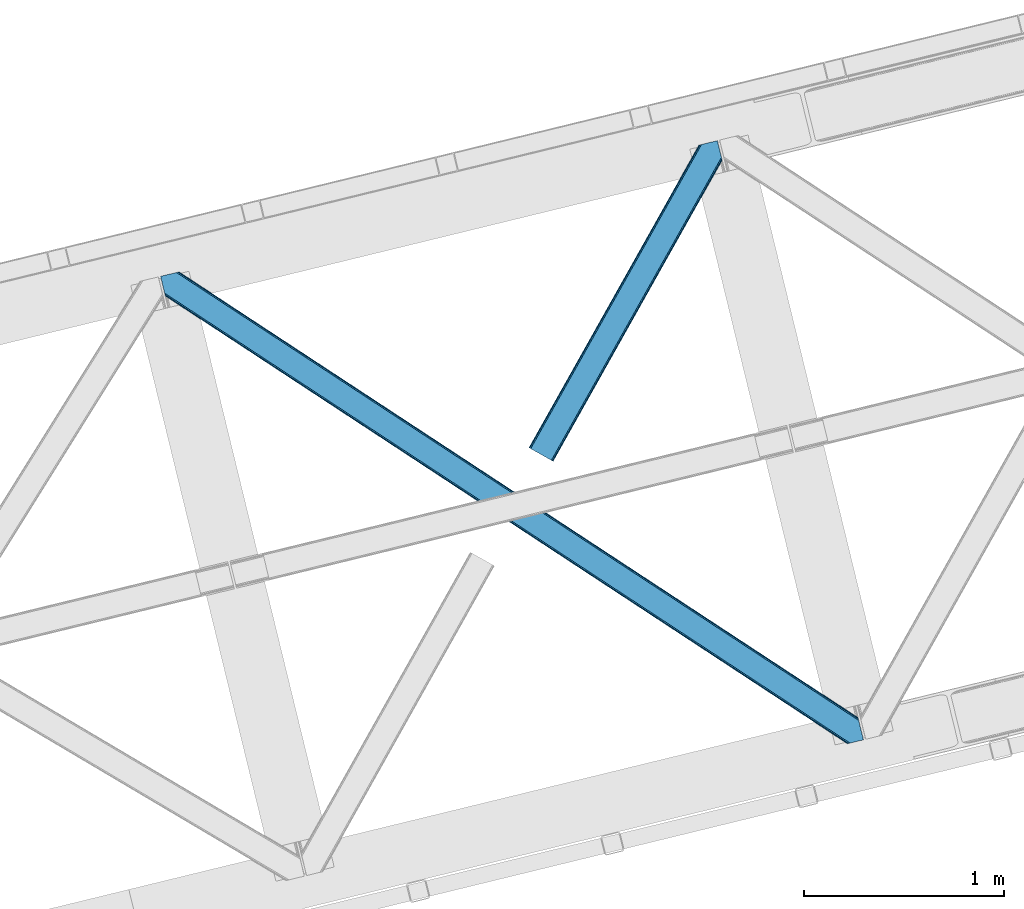
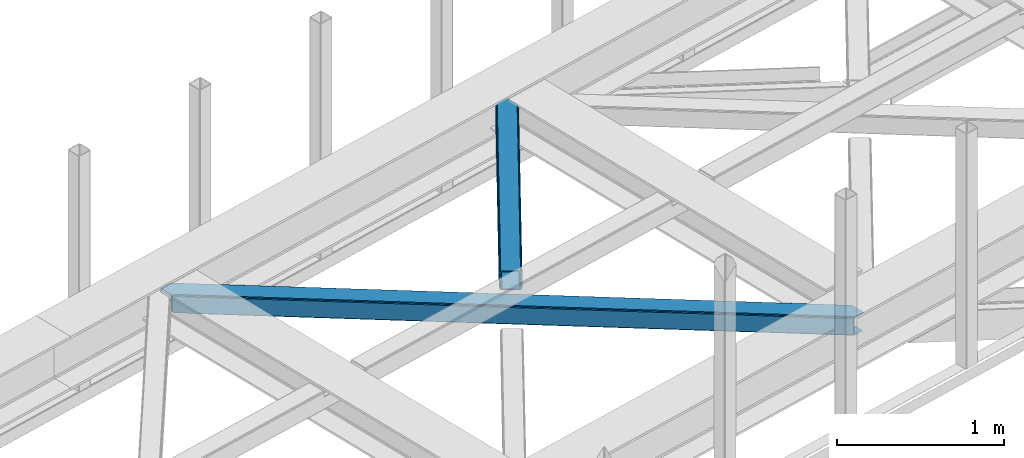
# One storey, part 54 of 66: 2 members.
"""IFC4 building model written with IfcOpenShell, lengths in millimetres."""

from ifc_helpers import new_model, entity, si_unit, converted_unit, derived_unit, direction, frame, origin, place, context, subcontext, project, spatial, triangles, type_object, element, save


model = new_model("IFC4")

# Units and contexts
model_context = context("Model", 3, precision=0.01, world=origin(), true_north=direction((6.12303176911189e-17, 1.0)))
plan_context = context("Plan", 3, precision=0.01, world=origin(), true_north=direction((6.12303176911189e-17, 1.0)))
body_context = subcontext(model_context, "Body", "Model", "MODEL_VIEW")
ifc_project = project(units=[si_unit("LENGTHUNIT", "METRE", prefix="MILLI"), si_unit("AREAUNIT", "SQUARE_METRE"), si_unit("VOLUMEUNIT", "CUBIC_METRE"), converted_unit("PLANEANGLEUNIT", "DEGREE", entity("IfcRatioMeasure", 0.0174532925199433), si_unit("PLANEANGLEUNIT", "RADIAN"), dimensions=[0, 0, 0, 0, 0, 0, 0]), si_unit("MASSUNIT", "GRAM", prefix="KILO"), derived_unit("MASSDENSITYUNIT", [(si_unit("MASSUNIT", "GRAM", prefix="KILO"), 1), (si_unit("LENGTHUNIT", "METRE"), -3)]), derived_unit("MOMENTOFINERTIAUNIT", [(si_unit("LENGTHUNIT", "METRE"), 4)]), si_unit("TIMEUNIT", "SECOND"), si_unit("FREQUENCYUNIT", "HERTZ"), si_unit("THERMODYNAMICTEMPERATUREUNIT", "DEGREE_CELSIUS"), derived_unit("THERMALTRANSMITTANCEUNIT", [(si_unit("MASSUNIT", "GRAM", prefix="KILO"), 1), (si_unit("THERMODYNAMICTEMPERATUREUNIT", "KELVIN"), -1), (si_unit("TIMEUNIT", "SECOND"), -3)]), derived_unit("VOLUMETRICFLOWRATEUNIT", [(si_unit("LENGTHUNIT", "METRE"), 3), (si_unit("TIMEUNIT", "SECOND"), -1)]), derived_unit("MASSFLOWRATEUNIT", [(si_unit("MASSUNIT", "GRAM", prefix="KILO"), 1), (si_unit("TIMEUNIT", "SECOND"), -1)]), derived_unit("ROTATIONALFREQUENCYUNIT", [(si_unit("TIMEUNIT", "SECOND"), -1)]), si_unit("ELECTRICCURRENTUNIT", "AMPERE"), si_unit("ELECTRICVOLTAGEUNIT", "VOLT"), si_unit("POWERUNIT", "WATT"), si_unit("FORCEUNIT", "NEWTON", prefix="KILO"), si_unit("ILLUMINANCEUNIT", "LUX"), si_unit("LUMINOUSFLUXUNIT", "LUMEN"), si_unit("LUMINOUSINTENSITYUNIT", "CANDELA"), derived_unit("USERDEFINED", [(si_unit("MASSUNIT", "GRAM", prefix="KILO"), -1), (si_unit("LENGTHUNIT", "METRE"), -2), (si_unit("TIMEUNIT", "SECOND"), 3), (si_unit("LUMINOUSFLUXUNIT", "LUMEN"), 1)]), derived_unit("LINEARVELOCITYUNIT", [(si_unit("LENGTHUNIT", "METRE"), 1), (si_unit("TIMEUNIT", "SECOND"), -1)]), si_unit("PRESSUREUNIT", "PASCAL"), derived_unit("USERDEFINED", [(si_unit("LENGTHUNIT", "METRE"), -2), (si_unit("MASSUNIT", "GRAM", prefix="KILO"), 1), (si_unit("TIMEUNIT", "SECOND"), -2)]), derived_unit("LINEARFORCEUNIT", [(si_unit("MASSUNIT", "GRAM", prefix="KILO"), 1), (si_unit("LENGTHUNIT", "METRE"), 1), (si_unit("TIMEUNIT", "SECOND"), -2), (si_unit("LENGTHUNIT", "METRE"), -1)]), derived_unit("PLANARFORCEUNIT", [(si_unit("MASSUNIT", "GRAM", prefix="KILO"), 1), (si_unit("LENGTHUNIT", "METRE"), 1), (si_unit("TIMEUNIT", "SECOND"), -2), (si_unit("LENGTHUNIT", "METRE"), -2)])], contexts=[model_context, plan_context])

# Site, building, storey
site_placement = place(None, origin())
site = spatial("IfcSite", under=ifc_project, at=site_placement, CompositionType="ELEMENT")
building_placement = place(site_placement, origin())
building = spatial("IfcBuilding", under=site, at=building_placement, CompositionType="ELEMENT")
storey_placement = place(building_placement, frame((0.0, 0.0, 19800.0)))
storey = spatial("IfcBuildingStorey", under=building, at=storey_placement, Name="06", CompositionType="ELEMENT", Elevation=19800.0)

# Members
member_type_1 = type_object("IfcMemberType", PredefinedType="BRACE")
member_1_placement = place(storey_placement, frame((-11734.97, 15585.64, 3823.0)))
element("IfcMember", 1, at=member_1_placement, inside=storey, type_object=member_type_1, ObjectType="Steel Horizontal Brace", PredefinedType="BRACE", context=body_context, shape_type="Tessellation", body=[
    triangles([(2937.7294052124, 494.760498046875, 17.5012573242202), (3489.95093078613, 132.252392578124, 122.499499511719), (3489.95093078613, 132.252392578124, 17.5012573242202), (2364.46672210693, 871.079388427734, 17.5012573242202), (1791.19996948242, 1247.39827880859, 17.5012573242202), (93.3036071777333, 2361.98373413086, 122.499499511719), (644.675765991211, 2000.03838500976, 17.5012573242202), (93.3036071777333, 2361.98373413086, 17.5012573242202), (1217.93728637695, 1623.71833190918, 17.5012573242202), (3496.02555999756, 107.331820678712, 140.00075683594), (3493.70128326416, 116.868447875977, 138.668280029298), (70.0515380859379, 2356.31547546387, 140.00075683594), (78.9486694335938, 2358.48394775391, 138.668280029298), (3491.73047332764, 124.954000854492, 134.87548828125), (86.4947204589844, 2360.32337036133, 134.87548828125), (3490.41311187744, 130.355996704102, 129.196765136719), (91.5327850341801, 2361.5523651123, 129.196765136719), (18.1488922119133, 2264.78617858887, 140.00075683594), (0.0, 2339.23977355957, 140.00075683594), (3459.55685577393, 5.66825866699219, 140.00075683594), (3517.37193145752, 19.761584472657, 140.00075683594), (3436.30420532227, 0.0, 122.499499511719), (3438.07560882568, 0.431369018555415, 129.196765136719), (24.2241027832024, 2239.86444396973, 122.499499511719), (23.7613403320302, 2241.76083984375, 129.196765136719), (3443.11367340088, 1.66036376953161, 134.87548828125), (22.4439788818363, 2247.16399841309, 134.87548828125), (3450.65972442627, 3.49978637695313, 138.668280029298), (20.4731689453129, 2255.24838867188, 138.668280029298), (1732.10008850098, 1118.72590026855, 17.5012573242202), (2308.23352661133, 740.523403930663, 17.5012573242202), (2884.36754608154, 362.320907592773, 17.5012573242202), (3436.30420532227, 0.0, 17.5012573242202), (1155.9701385498, 1496.92839660645, 17.5012573242202), (579.836700439453, 1875.13089294434, 17.5012573242202), (24.2241027832024, 2239.86444396973, 17.5012573242202), (21.3312561035145, 2251.7299987793, 122.197192382813), (20.0138946533207, 2257.13199462891, 127.873590087893), (21.7940185546868, 2249.83244018555, 115.499926757813), (21.7940185546868, 2249.83244018555, 24.5008300781265), (21.2382385253895, 2252.11137084961, 17.8686767578147), (21.1254547119133, 2252.57413330078, 16.5199218750022), (24.2136383056641, 2239.90397644043, 16.5199218750022), (18.0430847167972, 2265.21754760742, 131.668707275392), (15.7188079833977, 2274.75417480469, 133.001184082033), (0.0, 2339.23977355957, 133.001184082033), (3468.86035766602, 7.93556213378906, 133.001184082033), (3459.96322631836, 5.76708984375, 131.668707275392), (3452.41775665283, 3.92766723632849, 127.873590087893), (3447.37504119873, 2.69867248535229, 122.197192382813), (3445.60828857422, 2.26846618652417, 115.499926757813), (2899.81544036865, 360.552410888671, 24.5008300781265), (3445.60828857422, 2.26846618652417, 24.5008300781265), (2319.7380569458, 741.344284057617, 24.5008300781265), (1739.66009216309, 1122.13499450684, 24.5008300781265), (579.508813476563, 1883.71874084473, 24.5008300781265), (1159.58735961914, 1502.92803039551, 24.5008300781265), (60.7474548339833, 2354.04817199707, 133.001184082033), (3498.45564422607, 97.3626617431637, 133.001184082033), (3517.37193145752, 19.761584472657, 133.001184082033), (3492.38101501465, 122.284396362305, 115.499926757813), (3492.84319610596, 120.386837768554, 122.197192382813), (82.2333526611328, 2359.28506164551, 122.197192382813), (84.0041748046879, 2359.71759338379, 115.499926757813), (3494.15997619629, 114.984841918946, 127.873590087893), (77.1906372070316, 2358.05606689453, 127.873590087893), (3496.13078613281, 106.899288940429, 131.668707275392), (69.6492370605465, 2356.21780700684, 131.668707275392), (1789.35473327637, 1240.23941345215, 24.5008300781265), (2366.84622802734, 861.141622924806, 24.5008300781265), (2944.34237365723, 482.043832397461, 24.5008300781265), (3492.38101501465, 122.284396362305, 24.5008300781265), (1211.85858764648, 1619.33604125976, 24.5008300781265), (634.362442016602, 1998.43383178711, 24.5008300781265), (84.0041748046879, 2359.71759338379, 24.5008300781265), (82.2333526611328, 2359.28506164551, 17.8035644531265), (91.1804809570313, 2361.46632385254, 10.8691040039084), (90.7467864990231, 2361.36051635742, 9.52034912109593), (77.1906372070316, 2358.05606689453, 12.1248413085959), (72.7711395263668, 2356.97938842774, 9.52034912109593), (3494.1646270752, 114.986004638671, 127.873590087893), (3491.73919372559, 124.956326293945, 134.87548828125), (3493.71000366211, 116.87077331543, 138.668280029298), (3498.46029510498, 97.363824462891, 133.001184082033), (3496.13543701172, 106.900451660156, 131.668707275392), (3496.03486175537, 107.332983398437, 140.00075683594), (3517.35856018066, 19.7580963134769, 133.001184082033), (3517.36262969971, 19.7592590332024, 140.00075683594), (3490.13871002197, 131.207107543945, 12.5201660156272), (3492.77982788086, 120.37172241211, 17.8035644531265), (3494.03556518555, 115.201107788085, 12.2132080078118), (3489.89221343994, 132.238439941406, 17.5012573242202), (3489.95558166504, 132.253555297852, 122.499499511719), (3492.32229766846, 122.270443725585, 24.5008300781265), (3492.37636413574, 122.283233642578, 115.499926757813), (3490.42241363525, 130.358322143555, 129.196765136719), (30.6016204833977, 2237.5390045166, 10.8714294433594), (27.4366973876949, 2256.23902587891, 9.52034912109593), (25.3949615478505, 2253.59616394043, 12.1248413085959), (32.1329223632802, 2236.97508544922, 9.52034912109593), (161.614553833007, 2168.15486755371, 9.52034912109593), (143.640069580078, 2163.77373962402, 9.52034912109593), (580.237838745117, 1884.83262634277, 17.8035644531265), (582.322595214844, 1888.00452575683, 12.1248413085959), (585.436358642577, 1892.74958496094, 8.3320495605476), (589.112878417969, 1898.34808044434, 6.99957275390625), (173.638238525391, 2171.08608398437, 6.99957275390625), (164.935281372071, 2168.9641204834, 8.82504272460938), (3459.96322631836, 5.76708984375, 8.3320495605476), (3468.86035766602, 7.93556213378906, 6.99957275390625), (2909.4189239502, 375.181750488282, 6.99957275390625), (2905.7424041748, 369.583255004884, 8.3320495605476), (3452.41775665283, 3.92766723632849, 12.1248413085959), (2902.62922210693, 364.837033081054, 12.1248413085959), (3447.37504119873, 2.69867248535229, 17.8035644531265), (2900.54446563721, 361.665133666993, 17.8035644531265), (2320.47173309326, 742.458169555664, 17.8035644531265), (1740.39376831055, 1123.25004272461, 17.8035644531265), (1160.3163848877, 1504.04075317383, 17.8035644531265), (2322.55183868408, 745.62890625, 12.1248413085959), (1742.47387390137, 1126.42077941895, 12.1248413085959), (1162.39649047852, 1507.21148986816, 12.1248413085959), (2325.66502075195, 750.373965454102, 8.3320495605476), (1745.59228820801, 1131.16700134277, 8.3320495605476), (1165.51374206543, 1511.95887451172, 8.3320495605476), (2329.34095916748, 755.973623657226, 6.99957275390625), (1749.26299438477, 1136.76433410645, 6.99957275390625), (1169.19026184082, 1517.55736999512, 6.99957275390625), (3442.60789031982, 1.53711547851526, 5.52059326172093), (3438.07560882568, 0.431369018555415, 10.8039916992202), (3510.57176513672, 18.1035461425781, 5.52059326172093), (3512.00830535889, 18.4535247802742, 6.99957275390625), (3493.80534667969, 115.144134521484, 12.2132080078118), (3483.02053985596, 131.129205322266, 5.52059326172093), (3488.60333862305, 131.20245666504, 10.9621215820334), (3491.00144805908, 110.268850708007, 8.3320495605476), (3490.20207824707, 131.222222900391, 12.5201660156272), (3491.69094085693, 101.803088378907, 6.99957275390625), (1202.25568542481, 1604.70670166016, 6.99957275390625), (624.759539794921, 1983.8044921875, 6.99957275390625), (1779.74718017578, 1225.60891113281, 6.99957275390625), (198.048376464843, 2177.0357208252, 6.99957275390625), (172.834799194336, 2280.4712677002, 6.99957275390625), (2934.73947143555, 467.414492797852, 6.99957275390625), (2357.24332580566, 846.512283325195, 6.99957275390625), (628.434896850586, 1989.4029876709, 8.3320495605476), (170.517498779296, 2289.97650146484, 8.42274169921802), (2938.41540985107, 473.012988281251, 8.3320495605476), (2941.52859191894, 477.759210205078, 12.1248413085959), (3492.84319610596, 120.386837768554, 17.8035644531265), (631.54866027832, 1994.148046875, 12.1248413085959), (168.980383300781, 2293.67046203613, 9.44360961914208), (169.43733215332, 2292.66005859375, 9.13665161133031), (169.896606445313, 2291.64035339356, 8.82736816406396), (168.468786621093, 2294.15996704101, 9.52034912109593), (633.62876586914, 1997.31878356934, 17.8035644531265), (2943.61334838867, 480.931109619141, 17.8035644531265), (2360.91926422119, 852.110778808594, 8.3320495605476), (1783.42369995117, 1231.20740661621, 8.3320495605476), (1205.92755432129, 1610.30403442383, 8.3320495605476), (2364.03709716797, 856.857000732423, 12.1248413085959), (1786.54095153809, 1235.95479125977, 12.1248413085959), (1209.0448059082, 1615.05141906738, 12.1248413085959), (2366.11720275879, 860.027737426757, 17.8035644531265), (1788.62105712891, 1239.1255279541, 17.8035644531265), (1211.12491149902, 1618.22215576172, 17.8035644531265), (164.479495239257, 2312.62628173828, 9.02037963867406), (165.189916992187, 2311.83098144531, 8.52041015625218), (163.772561645508, 2313.4239074707, 9.52034912109593), (166.108465576172, 2308.06260681152, 5.12526855468968), (170.40471496582, 2290.44042663574, 0.0), (168.079275512695, 2299.97705383301, 1.33247680664135), (198.048376464843, 2177.0357208252, 0.0), (164.338806152344, 2168.81878051758, 0.0), (155.438186645508, 2166.64914550781, 1.33247680664135), (147.892135620117, 2164.80972290039, 5.12526855468968), (643.942089843749, 1998.92333679199, 10.8039916992202), (3361.49016723633, 210.375531005859, 5.21363525390552), (2937.00037994385, 493.646612548828, 10.8039916992202), (2934.91562347412, 490.474713134765, 5.12526855468968), (3354.02957611084, 208.557037353516, 1.33247680664135), (641.86198425293, 1995.75260009766, 5.12526855468968), (638.743569946289, 1991.00637817383, 1.33247680664135), (635.071701049805, 1985.40788269043, 0.0), (3345.12837524414, 206.387402343749, 0.0), (2931.80244140625, 485.729653930664, 1.33247680664135), (2928.12592163086, 480.131158447266, 0.0), (2363.73304595947, 869.965502929688, 10.8039916992202), (1790.47094421387, 1246.28555603027, 10.8039916992202), (1217.2082611084, 1622.60560913086, 10.8039916992202), (2361.65294036865, 866.794766235351, 5.12526855468968), (1788.39083862305, 1243.11481933594, 5.12526855468968), (1215.12350463867, 1619.4337097168, 5.12526855468968), (2358.53510742187, 862.048544311525, 1.33247680664135), (1785.27242431641, 1238.36743469238, 1.33247680664135), (1212.01090393066, 1614.68748779297, 1.33247680664135), (2354.86381988525, 856.450048828126, 0.0), (1781.59706726074, 1232.76893920899, 0.0), (1208.33438415527, 1609.08899230957, 0.0), (589.439602661132, 1889.76023254394, 0.0), (1165.57304077148, 1511.55889892578, 0.0), (1741.70299072266, 1133.35523986816, 0.0), (2893.97044830322, 376.950247192382, 0.0), (2317.83642883301, 755.152743530274, 0.0), (3315.15171661377, 199.079708862304, 0.0), (3343.77031860352, 81.6775726318356, 0.0), (580.565725708007, 1876.24477844238, 10.8039916992202), (582.650482177734, 1879.41667785645, 5.12526855468968), (2887.18132781982, 366.605529785156, 5.12526855468968), (2890.2945098877, 371.351751708984, 1.33247680664135), (3346.09459533691, 72.139782714843, 1.33247680664135), (3347.84448852539, 64.9611511230469, 4.52065429687718), (2885.0965713501, 363.433630371093, 10.8039916992202), (3348.63630065918, 63.8344757080085, 5.02062377929906), (3349.42346191406, 62.7066375732429, 5.52059326172093), (585.763082885742, 1884.16173706055, 1.33247680664135), (2314.16049041748, 749.553085327148, 1.33247680664135), (1738.03112182617, 1127.75674438477, 1.33247680664135), (1161.89768371582, 1505.95924072266, 1.33247680664135), (2311.04730834961, 744.808026123046, 5.12526855468968), (1734.91387023926, 1123.01052246094, 5.12526855468968), (1158.77926940918, 1501.21301879883, 5.12526855468968), (2308.96255187988, 741.636126708985, 10.8039916992202), (1732.83376464844, 1119.8397857666, 10.8039916992202), (1156.69916381836, 1498.04228210449, 10.8039916992202), (3349.42346191406, 62.7066375732429, 5.51129150390625), (3361.48958587646, 210.375531005859, 5.38339233398438), (3483.02053985596, 131.129205322266, 5.43687744140698), (3316.12316894531, 199.316903686524, 5.39734497070458), (3442.60789031982, 1.53711547851526, 5.55314941406323), (3510.57176513672, 18.1035461425781, 5.53222045898656), (3316.12316894531, 199.316903686524, 5.52059326172093), (3315.15171661377, 199.079708862304, 4.52065429687718)], [[1, 2, 3], [2, 1, 4], [2, 5, 6], [5, 2, 4], [7, 8, 6], [9, 6, 5], [6, 9, 7], [10, 11, 12], [13, 12, 11], [11, 14, 13], [15, 13, 14], [14, 16, 15], [17, 15, 16], [16, 2, 17], [6, 17, 2], [12, 18, 10], [12, 19, 18], [20, 10, 18], [21, 10, 20], [22, 23, 24], [25, 24, 23], [23, 26, 25], [27, 25, 26], [26, 28, 27], [29, 27, 28], [28, 20, 29], [18, 29, 20], [30, 22, 24], [22, 31, 32], [30, 31, 22], [32, 33, 22], [34, 24, 35], [24, 34, 30], [36, 35, 24], [37, 27, 38], [39, 40, 24], [25, 37, 24], [37, 25, 27], [37, 39, 24], [40, 36, 24], [41, 42, 43], [43, 36, 41], [40, 41, 36], [44, 29, 18], [19, 45, 18], [46, 45, 19], [44, 38, 29], [29, 38, 27], [45, 44, 18], [47, 48, 44], [44, 45, 47], [48, 49, 38], [38, 44, 48], [49, 50, 37], [37, 38, 49], [50, 51, 39], [39, 37, 50], [52, 51, 53], [51, 52, 54], [51, 55, 39], [55, 51, 54], [56, 40, 39], [57, 39, 55], [39, 57, 56], [45, 58, 59], [58, 45, 46], [59, 47, 45], [60, 47, 59], [61, 62, 63], [63, 64, 61], [62, 65, 66], [66, 63, 62], [65, 67, 68], [68, 66, 65], [67, 59, 58], [58, 68, 67], [69, 61, 64], [61, 70, 71], [69, 70, 61], [71, 72, 61], [73, 64, 74], [64, 73, 69], [75, 74, 64], [66, 68, 13], [15, 66, 13], [15, 17, 63], [66, 15, 63], [63, 17, 6], [68, 12, 13], [19, 58, 46], [19, 12, 58], [68, 58, 12], [63, 6, 64], [75, 8, 76], [6, 75, 64], [8, 77, 76], [6, 8, 75], [78, 76, 77], [79, 76, 78], [80, 79, 78], [81, 82, 83], [82, 81, 62], [84, 85, 86], [85, 81, 83], [87, 84, 88], [86, 88, 84], [85, 83, 86], [89, 90, 91], [92, 93, 94], [94, 90, 92], [89, 92, 90], [93, 95, 94], [62, 96, 82], [93, 96, 62], [95, 93, 62], [97, 98, 99], [97, 100, 98], [99, 43, 97], [42, 43, 99], [100, 98, 101], [101, 102, 100], [103, 104, 99], [99, 42, 103], [103, 41, 40], [105, 106, 107], [104, 105, 108], [108, 101, 104], [104, 101, 99], [98, 99, 101], [107, 108, 105], [109, 110, 111], [111, 112, 109], [113, 109, 112], [112, 114, 113], [115, 113, 114], [114, 116, 115], [53, 115, 116], [116, 52, 53], [40, 56, 103], [42, 41, 103], [52, 116, 54], [117, 54, 116], [54, 117, 118], [118, 55, 54], [55, 118, 119], [119, 57, 55], [57, 119, 103], [103, 56, 57], [116, 114, 120], [120, 117, 116], [117, 120, 121], [121, 118, 117], [118, 121, 119], [122, 119, 121], [119, 122, 103], [104, 103, 122], [114, 112, 120], [123, 120, 112], [120, 123, 124], [124, 121, 120], [121, 124, 125], [125, 122, 121], [122, 125, 105], [105, 104, 122], [112, 111, 126], [126, 123, 112], [123, 126, 127], [127, 124, 123], [124, 127, 125], [128, 125, 127], [125, 128, 106], [106, 105, 125], [49, 48, 28], [26, 49, 28], [50, 26, 23], [50, 22, 51], [26, 50, 49], [22, 50, 23], [48, 20, 28], [21, 47, 60], [21, 20, 47], [48, 47, 20], [22, 53, 51], [129, 113, 115], [115, 53, 33], [33, 53, 22], [115, 130, 129], [130, 115, 33], [131, 110, 129], [110, 109, 129], [109, 113, 129], [131, 132, 110], [133, 134, 135], [136, 134, 133], [135, 137, 133], [132, 131, 138], [138, 134, 136], [134, 138, 131], [139, 140, 106], [106, 128, 139], [128, 141, 139], [141, 128, 127], [106, 142, 107], [142, 140, 143], [106, 140, 142], [138, 144, 111], [111, 110, 138], [132, 138, 110], [144, 126, 111], [145, 127, 126], [127, 145, 141], [144, 145, 126], [146, 147, 143], [148, 136, 133], [149, 133, 150], [151, 152, 153], [153, 146, 151], [153, 154, 146], [154, 147, 146], [155, 151, 79], [79, 80, 155], [151, 156, 76], [76, 79, 151], [156, 74, 75], [75, 76, 156], [150, 72, 157], [71, 157, 72], [150, 157, 149], [133, 149, 148], [138, 136, 144], [148, 144, 136], [143, 140, 146], [144, 148, 145], [158, 145, 148], [145, 158, 141], [159, 141, 158], [141, 159, 160], [160, 139, 141], [139, 160, 146], [146, 140, 139], [148, 149, 161], [161, 158, 148], [158, 161, 159], [162, 159, 161], [159, 162, 160], [163, 160, 162], [160, 163, 146], [151, 146, 163], [149, 157, 164], [164, 161, 149], [161, 164, 165], [165, 162, 161], [162, 165, 163], [166, 163, 165], [163, 166, 151], [156, 151, 166], [157, 71, 70], [70, 164, 157], [164, 70, 69], [69, 165, 164], [165, 69, 73], [73, 166, 165], [166, 73, 74], [74, 156, 166], [167, 153, 152], [168, 154, 153], [168, 147, 154], [80, 78, 169], [169, 155, 80], [147, 168, 170], [171, 147, 172], [170, 172, 147], [147, 171, 143], [143, 173, 142], [173, 143, 171], [108, 107, 174], [101, 174, 175], [175, 176, 101], [173, 107, 142], [107, 173, 174], [176, 102, 101], [174, 101, 108], [177, 77, 8], [1, 137, 135], [1, 3, 137], [135, 134, 178], [178, 179, 135], [180, 178, 181], [77, 177, 169], [177, 182, 170], [170, 168, 177], [177, 168, 167], [167, 169, 177], [169, 78, 77], [182, 183, 172], [172, 170, 182], [183, 184, 171], [171, 172, 183], [181, 185, 186], [187, 186, 185], [181, 186, 180], [178, 180, 179], [135, 179, 1], [8, 7, 177], [1, 179, 4], [188, 4, 179], [4, 188, 5], [189, 5, 188], [5, 189, 190], [190, 9, 5], [9, 190, 177], [177, 7, 9], [179, 180, 188], [191, 188, 180], [188, 191, 189], [192, 189, 191], [189, 192, 190], [193, 190, 192], [190, 193, 177], [182, 177, 193], [180, 186, 194], [194, 191, 180], [191, 194, 195], [195, 192, 191], [192, 195, 193], [196, 193, 195], [193, 196, 182], [183, 182, 196], [186, 187, 197], [197, 194, 186], [194, 197, 198], [198, 195, 194], [195, 198, 199], [199, 196, 195], [196, 199, 184], [184, 183, 196], [200, 174, 173], [184, 200, 173], [184, 173, 171], [199, 200, 184], [201, 200, 199], [198, 201, 199], [201, 198, 202], [187, 203, 204], [202, 197, 204], [197, 202, 198], [197, 187, 204], [187, 205, 203], [203, 205, 206], [185, 205, 187], [35, 36, 97], [36, 43, 97], [207, 97, 102], [102, 208, 207], [102, 176, 208], [97, 100, 102], [209, 210, 211], [211, 212, 209], [213, 209, 214], [130, 33, 213], [32, 213, 33], [129, 130, 215], [213, 215, 130], [212, 214, 209], [206, 211, 210], [210, 203, 206], [200, 216, 174], [175, 174, 216], [216, 208, 175], [176, 175, 208], [97, 207, 35], [203, 210, 204], [217, 204, 210], [204, 217, 202], [218, 202, 217], [202, 218, 219], [219, 201, 202], [201, 219, 200], [216, 200, 219], [210, 209, 217], [220, 217, 209], [217, 220, 218], [221, 218, 220], [218, 221, 219], [222, 219, 221], [219, 222, 208], [208, 216, 219], [209, 213, 223], [223, 220, 209], [220, 223, 221], [224, 221, 223], [221, 224, 222], [225, 222, 224], [222, 225, 208], [207, 208, 225], [213, 32, 31], [31, 223, 213], [223, 31, 224], [30, 224, 31], [224, 30, 34], [34, 225, 224], [225, 34, 35], [35, 207, 225], [226, 227, 228], [227, 226, 229], [228, 230, 226], [231, 230, 228], [185, 232, 205], [178, 185, 181], [205, 232, 233], [178, 232, 185], [206, 233, 212], [206, 205, 233], [212, 211, 206]]),
])
member_type_2 = type_object("IfcMemberType", PredefinedType="BRACE")
member_2_placement = place(storey_placement, frame((-9892.02, 16998.99, 3823.0)))
element("IfcMember", 2, at=member_2_placement, inside=storey, type_object=member_type_2, ObjectType="Steel Horizontal Brace", PredefinedType="BRACE", context=body_context, shape_type="Tessellation", body=[
    triangles([(963.930697631835, 1521.10947875976, 138.668280029298), (961.605839538573, 1530.64726867676, 140.00075683594), (106.810922241211, 8.56924438476563, 140.00075683594), (112.650100708008, 5.29037475585938, 138.668280029298), (965.901507568358, 1513.02508850098, 134.87548828125), (117.598635864257, 2.50914916992042, 134.87548828125), (967.21828765869, 1507.62192993164, 129.196765136719), (120.908898925782, 0.65228576660229, 129.196765136719), (967.680468749999, 1505.72553405762, 122.499499511719), (122.068130493164, 0.0, 122.499499511719), (967.680468749999, 1505.72553405762, 17.5012573242202), (122.068130493164, 0.0, 17.5012573242202), (15.2572082519528, 59.9835479736321, 140.00075683594), (873.405409240722, 1588.02516174316, 140.00075683594), (943.45694732666, 1605.10086364746, 140.00075683594), (851.919511413575, 1582.78827209473, 129.196765136719), (850.152758789061, 1582.35690307617, 122.499499511719), (1.16388244628797, 67.9005065917954, 129.196765136719), (0.0, 68.5527923583977, 122.499499511719), (856.962226867676, 1584.0172668457, 134.87548828125), (4.46949462890552, 66.04248046875, 134.87548828125), (864.503627014159, 1585.8555267334, 138.668280029298), (9.4215179443363, 63.2635803222656, 138.668280029298), (850.152758789061, 1582.35690307617, 17.5012573242202), (0.0, 68.5527923583977, 17.5012573242202), (1.16388244628797, 67.9005065917954, 10.8039916992202), (809.934864807128, 1506.81616516113, 9.52034912109593), (809.674415588379, 1505.78367004394, 9.02037963867406), (4.46949462890552, 66.04248046875, 5.12526855468968), (809.409315490722, 1504.7488494873, 8.52041015625218), (810.327864074707, 1500.98047485352, 5.12526855468968), (852.276466369629, 1582.87431335449, 10.8691040039084), (852.710160827637, 1582.98012084961, 9.52034912109593), (812.29867401123, 1492.89608459473, 1.33247680664135), (814.623532104491, 1483.35829467774, 0.0), (9.4215179443363, 63.2635803222656, 1.33247680664135), (15.2572082519528, 59.9835479736321, 0.0), (842.022441101073, 1370.95817871094, 0.0), (106.810922241211, 8.56924438476563, 0.0), (876.670907592774, 1379.40417480469, 0.0), (814.517724609375, 1484.6570526123, 8.82736816406396), (814.736315917968, 1482.89553222656, 8.42274169921802), (814.460751342773, 1485.77442626953, 9.13665161133031), (814.401452636719, 1486.88249816895, 9.44360961914208), (814.630508422852, 1487.55222473144, 9.52034912109593), (870.68522644043, 1587.36241149902, 9.52034912109593), (817.053616333007, 1473.39029846191, 6.99957275390625), (842.022441101073, 1370.95817871094, 6.99957275390625), (15.5234710693348, 59.8347198486335, 8.3320495605476), (21.3638122558586, 56.5558502197273, 6.99957275390625), (866.261659240723, 1586.28340759277, 12.1248413085959), (10.5714477539059, 62.6147827148452, 12.1248413085959), (861.223013305664, 1585.05557556152, 17.8035644531265), (859.452191162109, 1584.62420654297, 24.5008300781265), (7.26467285156286, 64.4728088378906, 17.8035644531265), (6.1054412841786, 65.1250946044929, 24.5008300781265), (100.704318237304, 11.9957794189468, 6.99957275390625), (867.366824340819, 1377.13687133789, 6.99957275390625), (885.567457580566, 1381.57380981445, 1.33247680664135), (879.391090393066, 1380.06808776856, 9.52034912109593), (893.113508605957, 1383.41323242187, 5.12526855468968), (876.06978149414, 1379.25767211914, 8.82504272460938), (897.365574645995, 1384.44921569824, 9.52034912109593), (963.083074951172, 1500.72467651367, 10.8714294433594), (120.908898925782, 0.65228576660229, 10.8039916992202), (117.598635864257, 2.50914916992042, 5.12526855468968), (967.671166992188, 1505.76390380859, 16.5199218750022), (961.988374328614, 1499.52126159668, 9.52034912109593), (112.650100708008, 5.29037475585938, 1.33247680664135), (960.31696472168, 1517.3771484375, 12.1248413085959), (964.582402038573, 1518.43522338867, 16.5199218750022), (957.29273071289, 1518.78520202637, 9.52034912109593), (114.803457641601, 4.07998352050708, 17.8035644531265), (115.967340087891, 3.42769775390479, 24.5008300781265), (965.250965881347, 1515.69353027344, 24.5008300781265), (964.69518585205, 1517.9724609375, 17.8686767578147), (111.496682739258, 5.93800964355614, 12.1248413085959), (106.544659423827, 8.71690979004052, 8.3320495605476), (965.250965881347, 1515.69353027344, 115.499926757813), (115.967340087891, 3.42769775390479, 115.499926757813), (964.788203430175, 1517.59108886719, 122.197192382813), (963.471423339843, 1522.9930847168, 127.873590087893), (961.500613403319, 1531.07863769531, 131.668707275392), (959.175755310058, 1540.61526489258, 133.001184082033), (943.45694732666, 1605.10086364746, 133.001184082033), (114.803457641601, 4.07998352050708, 122.197192382813), (111.496682739258, 5.93800964355614, 127.873590087893), (106.544659423827, 8.71690979004052, 131.668707275392), (100.704318237304, 11.9957794189468, 133.001184082033), (10.5714477539059, 62.6147827148452, 127.873590087893), (21.3638122558586, 56.5558502197273, 133.001184082033), (15.5234710693348, 59.8347198486335, 131.668707275392), (6.1054412841786, 65.1250946044929, 115.499926757813), (7.26467285156286, 64.4728088378906, 122.197192382813), (861.223013305664, 1585.05557556152, 122.197192382813), (873.807710266114, 1588.12283020019, 131.668707275392), (882.70484161377, 1590.29246520996, 133.001184082033), (866.261659240723, 1586.28340759277, 127.873590087893), (859.452191162109, 1584.62420654297, 115.499926757813)], [[1, 2, 3], [3, 4, 1], [5, 1, 4], [4, 6, 5], [7, 5, 6], [6, 8, 7], [9, 7, 8], [8, 10, 9], [11, 9, 10], [10, 12, 11], [13, 2, 14], [13, 3, 2], [2, 15, 14], [16, 17, 18], [19, 18, 17], [20, 16, 21], [18, 21, 16], [22, 20, 23], [21, 23, 20], [14, 22, 13], [23, 13, 22], [17, 24, 19], [25, 19, 24], [26, 25, 24], [27, 28, 29], [30, 29, 28], [30, 31, 29], [26, 32, 27], [27, 29, 26], [32, 33, 27], [34, 35, 36], [37, 36, 35], [31, 34, 29], [36, 29, 34], [24, 32, 26], [38, 37, 35], [39, 38, 40], [38, 39, 37], [41, 42, 30], [43, 41, 30], [44, 43, 28], [45, 27, 46], [33, 46, 27], [34, 42, 35], [30, 42, 31], [31, 42, 34], [47, 35, 42], [47, 38, 35], [38, 47, 48], [49, 50, 47], [44, 51, 52], [44, 46, 51], [52, 49, 42], [43, 52, 41], [43, 44, 52], [52, 42, 41], [47, 42, 49], [53, 54, 55], [56, 55, 54], [51, 53, 52], [55, 52, 53], [48, 57, 58], [50, 48, 47], [48, 50, 57], [59, 60, 61], [58, 38, 48], [58, 62, 40], [58, 40, 38], [40, 60, 59], [61, 60, 63], [62, 60, 40], [64, 65, 63], [65, 66, 61], [61, 63, 65], [12, 65, 64], [64, 11, 12], [64, 67, 11], [63, 68, 64], [59, 61, 66], [66, 69, 59], [40, 59, 69], [69, 39, 40], [70, 67, 64], [70, 71, 67], [64, 72, 70], [68, 72, 64], [63, 60, 68], [72, 68, 60], [73, 74, 75], [73, 71, 70], [73, 76, 71], [77, 70, 60], [60, 78, 77], [60, 62, 78], [70, 72, 60], [78, 62, 58], [58, 57, 78], [70, 77, 73], [75, 76, 73], [79, 75, 74], [74, 80, 79], [76, 67, 71], [9, 11, 75], [11, 76, 75], [75, 79, 9], [11, 67, 76], [81, 9, 79], [7, 9, 81], [5, 81, 82], [81, 5, 7], [82, 1, 5], [83, 1, 82], [83, 84, 2], [83, 2, 1], [84, 15, 2], [84, 85, 15], [81, 79, 86], [80, 86, 79], [82, 81, 87], [86, 87, 81], [83, 82, 88], [87, 88, 82], [84, 83, 89], [88, 89, 83], [8, 87, 86], [80, 12, 10], [8, 86, 10], [8, 6, 87], [86, 80, 10], [87, 6, 4], [89, 3, 13], [3, 88, 4], [88, 3, 89], [88, 87, 4], [65, 77, 66], [74, 12, 80], [12, 73, 65], [73, 12, 74], [65, 73, 77], [39, 57, 37], [69, 66, 77], [77, 78, 69], [78, 57, 39], [39, 69, 78], [90, 23, 21], [13, 91, 89], [13, 92, 91], [92, 13, 23], [90, 92, 23], [93, 19, 25], [18, 94, 90], [21, 18, 90], [94, 18, 19], [93, 94, 19], [36, 52, 29], [37, 57, 50], [50, 49, 37], [49, 52, 36], [36, 37, 49], [26, 29, 52], [25, 56, 93], [55, 25, 26], [25, 55, 56], [55, 26, 52], [95, 17, 16], [96, 22, 14], [15, 97, 14], [97, 15, 85], [97, 96, 14], [98, 22, 96], [98, 95, 20], [20, 22, 98], [16, 20, 95], [54, 24, 17], [51, 33, 53], [95, 99, 17], [51, 46, 33], [54, 53, 24], [99, 54, 17], [32, 24, 53], [53, 33, 32], [91, 84, 89], [84, 91, 97], [85, 84, 97], [54, 99, 93], [93, 56, 54], [96, 97, 91], [91, 92, 96], [98, 96, 92], [92, 90, 98], [95, 98, 90], [90, 94, 95], [99, 95, 94], [94, 93, 99]]),
])

save(model, "model.ifc")
